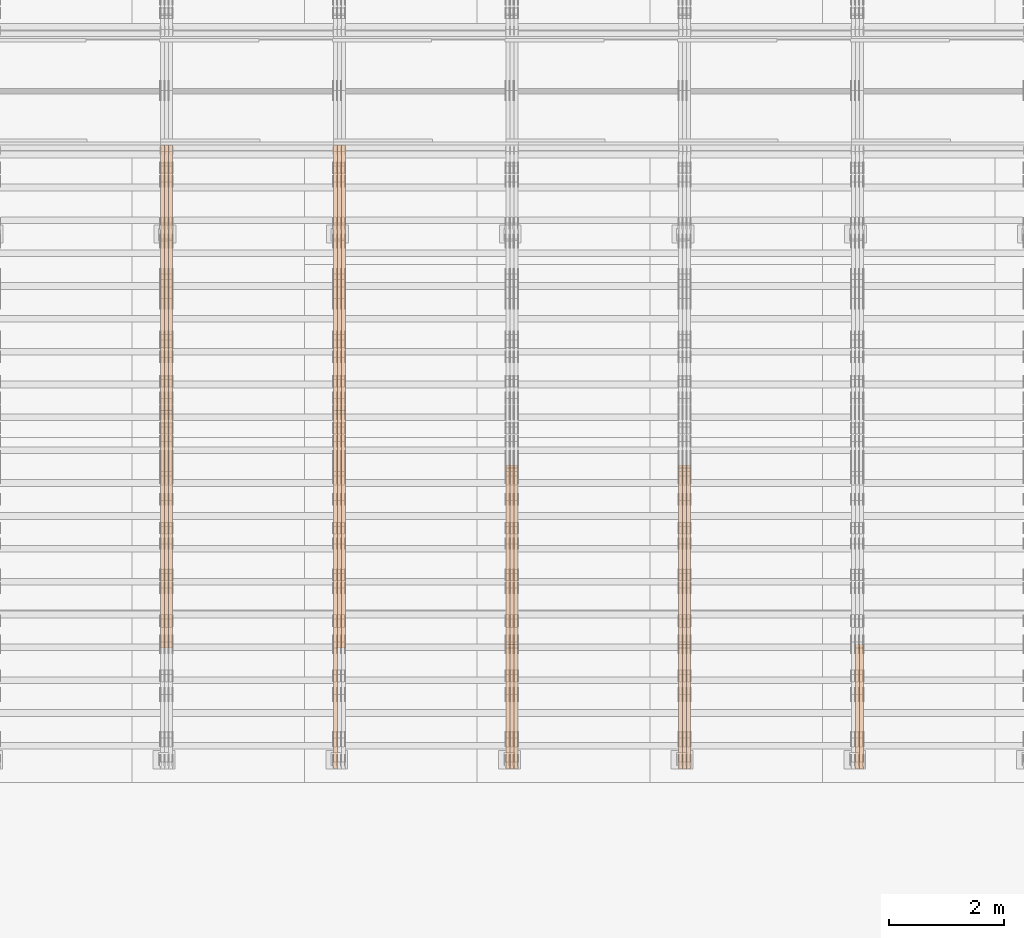
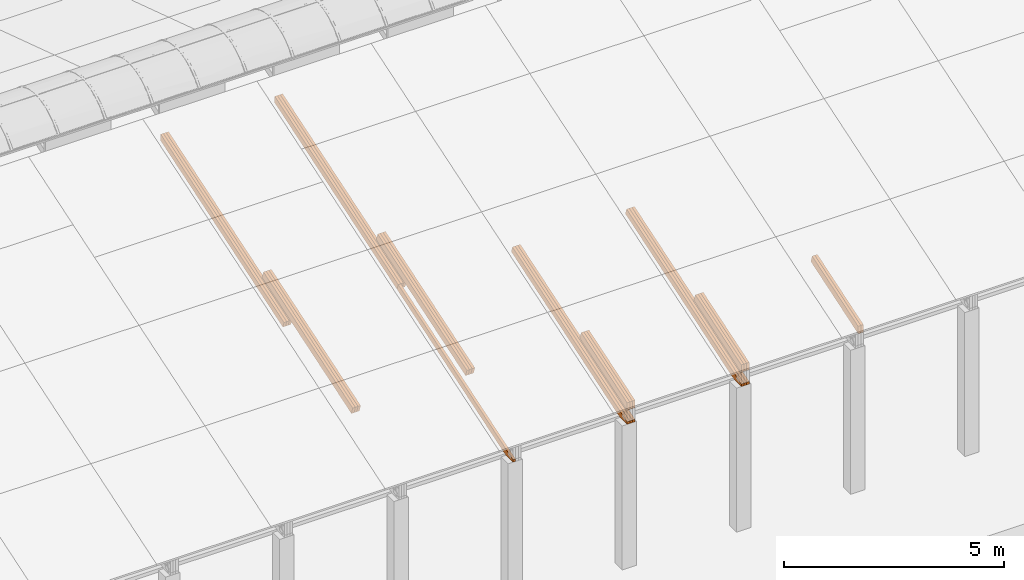
# One storey, part 16 of 385: 27 proxies.
"""IFC2X3 building model written with IfcOpenShell, lengths in millimetres."""

from ifc_helpers import new_model, entity, si_unit, converted_unit, derived_unit, direction, frame, origin, place, context, subcontext, project, spatial, polyline, outline, extrude, source, transform, mapped, material, type_object, type_shapes, element, save


model = new_model("IFC2X3")

# Units and contexts
model_context = context("Model", 3, precision=0.01, world=origin(), true_north=direction((6.12303176911189e-17, 1.0)))
body_context = subcontext(model_context, "Body", "Model", "MODEL_VIEW")
ifc_project = project(units=[si_unit("LENGTHUNIT", "METRE", prefix="MILLI"), si_unit("AREAUNIT", "SQUARE_METRE"), si_unit("VOLUMEUNIT", "CUBIC_METRE"), converted_unit("PLANEANGLEUNIT", "DEGREE", entity("IfcRatioMeasure", 0.0174532925199433), si_unit("PLANEANGLEUNIT", "RADIAN"), dimensions=[0, 0, 0, 0, 0, 0, 0]), si_unit("MASSUNIT", "GRAM", prefix="KILO"), derived_unit("MASSDENSITYUNIT", [(si_unit("MASSUNIT", "GRAM", prefix="KILO"), 1), (si_unit("LENGTHUNIT", "METRE"), -3)]), si_unit("TIMEUNIT", "SECOND"), si_unit("FREQUENCYUNIT", "HERTZ"), si_unit("THERMODYNAMICTEMPERATUREUNIT", "DEGREE_CELSIUS"), derived_unit("THERMALTRANSMITTANCEUNIT", [(si_unit("MASSUNIT", "GRAM", prefix="KILO"), 1), (si_unit("THERMODYNAMICTEMPERATUREUNIT", "KELVIN"), -1), (si_unit("TIMEUNIT", "SECOND"), -3)]), derived_unit("VOLUMETRICFLOWRATEUNIT", [(si_unit("LENGTHUNIT", "METRE"), 3), (si_unit("TIMEUNIT", "SECOND"), -1)]), si_unit("ELECTRICCURRENTUNIT", "AMPERE"), si_unit("ELECTRICVOLTAGEUNIT", "VOLT"), si_unit("POWERUNIT", "WATT"), si_unit("FORCEUNIT", "NEWTON", prefix="KILO"), si_unit("ILLUMINANCEUNIT", "LUX"), si_unit("LUMINOUSFLUXUNIT", "LUMEN"), si_unit("LUMINOUSINTENSITYUNIT", "CANDELA"), derived_unit("USERDEFINED", [(si_unit("MASSUNIT", "GRAM", prefix="KILO"), -1), (si_unit("LENGTHUNIT", "METRE"), -2), (si_unit("TIMEUNIT", "SECOND"), 3), (si_unit("LUMINOUSFLUXUNIT", "LUMEN"), 1)]), derived_unit("LINEARVELOCITYUNIT", [(si_unit("LENGTHUNIT", "METRE"), 1), (si_unit("TIMEUNIT", "SECOND"), -1)]), si_unit("PRESSUREUNIT", "PASCAL"), derived_unit("USERDEFINED", [(si_unit("LENGTHUNIT", "METRE"), -2), (si_unit("MASSUNIT", "GRAM", prefix="KILO"), 1), (si_unit("TIMEUNIT", "SECOND"), -2)])], contexts=[model_context])

# Site, building, storey
site_placement = place(None, origin())
site = spatial("IfcSite", under=ifc_project, at=site_placement, CompositionType="ELEMENT")
building_placement = place(site_placement, origin())
building = spatial("IfcBuilding", under=site, at=building_placement, CompositionType="ELEMENT")
storey_placement = place(building_placement, origin())
storey = spatial("IfcBuildingStorey", under=building, at=storey_placement, Name="Default", CompositionType="ELEMENT", Elevation=0.0)

# Proxies
ifc_material_1 = material(Name="IfcSurfaceStyle #352167")
building_element_proxy_type_1 = type_object("IfcBuildingElementProxyType", Name="T1-T3 352165", PredefinedType="NOTDEFINED", material=ifc_material_1)
shared_shape_1 = source(origin(), body_context, "Body", "SweptSolid", [
    extrude(outline(polyline([(-1085.54462735035, -97.5001496742589), (1117.22361141796, -97.5001496742589), (1117.22498157786, 97.5001496742589), (-1148.90396564547, 97.5001496742589), (-1085.54462735035, -97.5001496742589)])), frame((1117.22498157786, 97.5001496742589, 0.0), z_axis=(0.0, 0.0, 1.0), x_axis=(-1.0, 0.0, 0.0)), (0.0, 0.0, 1.0), 69.9999999999999),
])
type_shapes(building_element_proxy_type_1, [shared_shape_1])
proxy_1_placement = place(building_placement, frame((30385.0, 5095.216796875, 1095.23693847656), z_axis=(-1.0, 0.0, 0.0), x_axis=(0.0, -0.951056516295154, -0.309016994374948)))
element("IfcBuildingElementProxy", 1, at=proxy_1_placement, inside=storey, type_object=building_element_proxy_type_1, material=ifc_material_1, Name="T1-T3", context=body_context, shape_type="MappedRepresentation", body=[
    mapped(shared_shape_1, transform((0.0, 0.0, 0.0), scale=1.0)),
])
ifc_material_2 = material(Name="IfcSurfaceStyle #352110")
building_element_proxy_type_2 = type_object("IfcBuildingElementProxyType", Name="T1-T3 352108", PredefinedType="NOTDEFINED", material=ifc_material_2)
shared_shape_2 = source(origin(), body_context, "Body", "SweptSolid", [
    extrude(outline(polyline([(-1085.54462735035, -97.5001496742589), (1117.22361141796, -97.5001496742589), (1117.22498157786, 97.5001496742589), (-1148.90396564547, 97.5001496742589), (-1085.54462735035, -97.5001496742589)])), frame((1117.22498157786, 97.5001496742589, 0.0), z_axis=(0.0, 0.0, 1.0), x_axis=(-1.0, 0.0, 0.0)), (0.0, 0.0, 1.0), 69.9999999999999),
])
type_shapes(building_element_proxy_type_2, [shared_shape_2])
proxy_2_placement = place(building_placement, frame((30315.0, 5095.216796875, 1095.23693847656), z_axis=(-1.0, 0.0, 0.0), x_axis=(0.0, -0.951056516295154, -0.309016994374948)))
element("IfcBuildingElementProxy", 2, at=proxy_2_placement, inside=storey, type_object=building_element_proxy_type_2, material=ifc_material_2, Name="T1-T3", context=body_context, shape_type="MappedRepresentation", body=[
    mapped(shared_shape_2, transform((0.0, 0.0, 0.0), scale=1.0)),
])
ifc_material_3 = material(Name="IfcSurfaceStyle #317735")
building_element_proxy_type_3 = type_object("IfcBuildingElementProxyType", Name="T1-T3 317733", PredefinedType="NOTDEFINED", material=ifc_material_3)
shared_shape_3 = source(origin(), body_context, "Body", "SweptSolid", [
    extrude(outline(polyline([(-1085.54462735035, -97.5001496742589), (1117.22361141796, -97.5001496742589), (1117.22498157786, 97.5001496742589), (-1148.90396564547, 97.5001496742589), (-1085.54462735035, -97.5001496742589)])), frame((1117.22498157786, 97.5001496742589, 0.0), z_axis=(0.0, 0.0, 1.0), x_axis=(-1.0, 0.0, 0.0)), (0.0, 0.0, 1.0), 69.9999999999999),
])
type_shapes(building_element_proxy_type_3, [shared_shape_3])
proxy_3_placement = place(building_placement, frame((27385.0, 5095.216796875, 1095.23693847656), z_axis=(-1.0, 0.0, 0.0), x_axis=(0.0, -0.951056516295154, -0.309016994374948)))
element("IfcBuildingElementProxy", 3, at=proxy_3_placement, inside=storey, type_object=building_element_proxy_type_3, material=ifc_material_3, Name="T1-T3", context=body_context, shape_type="MappedRepresentation", body=[
    mapped(shared_shape_3, transform((0.0, 0.0, 0.0), scale=1.0)),
])
ifc_material_4 = material(Name="IfcSurfaceStyle #317678")
building_element_proxy_type_4 = type_object("IfcBuildingElementProxyType", Name="T1-T3 317676", PredefinedType="NOTDEFINED", material=ifc_material_4)
shared_shape_4 = source(origin(), body_context, "Body", "SweptSolid", [
    extrude(outline(polyline([(-1085.54462735035, -97.5001496742589), (1117.22361141796, -97.5001496742589), (1117.22498157786, 97.5001496742589), (-1148.90396564547, 97.5001496742589), (-1085.54462735035, -97.5001496742589)])), frame((1117.22498157786, 97.5001496742589, 0.0), z_axis=(0.0, 0.0, 1.0), x_axis=(-1.0, 0.0, 0.0)), (0.0, 0.0, 1.0), 69.9999999999999),
])
type_shapes(building_element_proxy_type_4, [shared_shape_4])
proxy_4_placement = place(building_placement, frame((27315.0, 5095.216796875, 1095.23693847656), z_axis=(-1.0, 0.0, 0.0), x_axis=(0.0, -0.951056516295154, -0.309016994374948)))
element("IfcBuildingElementProxy", 4, at=proxy_4_placement, inside=storey, type_object=building_element_proxy_type_4, material=ifc_material_4, Name="T1-T3", context=body_context, shape_type="MappedRepresentation", body=[
    mapped(shared_shape_4, transform((0.0, 0.0, 0.0), scale=1.0)),
])
ifc_material_5 = material(Name="IfcSurfaceStyle #317621")
building_element_proxy_type_5 = type_object("IfcBuildingElementProxyType", Name="T1-T3 317619", PredefinedType="NOTDEFINED", material=ifc_material_5)
shared_shape_5 = source(origin(), body_context, "Body", "SweptSolid", [
    extrude(outline(polyline([(-1085.54462735035, -97.5001496742589), (1117.22361141796, -97.5001496742589), (1117.22498157786, 97.5001496742589), (-1148.90396564547, 97.5001496742589), (-1085.54462735035, -97.5001496742589)])), frame((1117.22498157786, 97.5001496742589, 0.0), z_axis=(0.0, 0.0, 1.0), x_axis=(-1.0, 0.0, 0.0)), (0.0, 0.0, 1.0), 69.9999999999999),
])
type_shapes(building_element_proxy_type_5, [shared_shape_5])
proxy_5_placement = place(building_placement, frame((27245.0, 5095.216796875, 1095.23693847656), z_axis=(-1.0, 0.0, 0.0), x_axis=(0.0, -0.951056516295154, -0.309016994374948)))
element("IfcBuildingElementProxy", 5, at=proxy_5_placement, inside=storey, type_object=building_element_proxy_type_5, material=ifc_material_5, Name="T1-T3", context=body_context, shape_type="MappedRepresentation", body=[
    mapped(shared_shape_5, transform((0.0, 0.0, 0.0), scale=1.0)),
])
ifc_material_6 = material(Name="IfcSurfaceStyle #317051")
building_element_proxy_type_6 = type_object("IfcBuildingElementProxyType", Name="T1-B5 317049", PredefinedType="NOTDEFINED", material=ifc_material_6)
shared_shape_6 = source(origin(), body_context, "Body", "SweptSolid", [
    extrude(outline(polyline([(-3238.20553797979, -89.0131148793731), (1950.26357999126, -89.0131148793731), (2273.6227955316, 16.0525968934038), (2252.52438864378, 80.9868164326712), (-3238.20522618685, 80.9868164326712), (-3238.20553797979, -89.0131148793731)])), frame((2273.6227955316, 80.9869419088758, 0.0), z_axis=(0.0, 0.0, 1.0), x_axis=(-1.0, 0.0, 0.0)), (0.0, 0.0, 1.0), 69.9999999999997),
])
type_shapes(building_element_proxy_type_6, [shared_shape_6])
proxy_6_placement = place(building_placement, frame((27385.0, 2919.93418387161, 61.7562319586341), z_axis=(-1.0, 0.0, 0.0), x_axis=(0.0, 0.951056516295124, 0.309016994375039)))
element("IfcBuildingElementProxy", 6, at=proxy_6_placement, inside=storey, type_object=building_element_proxy_type_6, material=ifc_material_6, Name="T1-B5", context=body_context, shape_type="MappedRepresentation", body=[
    mapped(shared_shape_6, transform((0.0, 0.0, 0.0), scale=1.0)),
])
ifc_material_7 = material(Name="IfcSurfaceStyle #316985")
building_element_proxy_type_7 = type_object("IfcBuildingElementProxyType", Name="T1-B5 316983", PredefinedType="NOTDEFINED", material=ifc_material_7)
shared_shape_7 = source(origin(), body_context, "Body", "SweptSolid", [
    extrude(outline(polyline([(-3238.20553797979, -89.0131148793731), (1950.26357999126, -89.0131148793731), (2273.6227955316, 16.0525968934038), (2252.52438864378, 80.9868164326712), (-3238.20522618685, 80.9868164326712), (-3238.20553797979, -89.0131148793731)])), frame((2273.6227955316, 80.9869419088758, 0.0), z_axis=(0.0, 0.0, 1.0), x_axis=(-1.0, 0.0, 0.0)), (0.0, 0.0, 1.0), 69.9999999999997),
])
type_shapes(building_element_proxy_type_7, [shared_shape_7])
proxy_7_placement = place(building_placement, frame((27315.0, 2919.93418387161, 61.7562319586341), z_axis=(-1.0, 0.0, 0.0), x_axis=(0.0, 0.951056516295124, 0.309016994375039)))
element("IfcBuildingElementProxy", 7, at=proxy_7_placement, inside=storey, type_object=building_element_proxy_type_7, material=ifc_material_7, Name="T1-B5", context=body_context, shape_type="MappedRepresentation", body=[
    mapped(shared_shape_7, transform((0.0, 0.0, 0.0), scale=1.0)),
])
ifc_material_8 = material(Name="IfcSurfaceStyle #316919")
building_element_proxy_type_8 = type_object("IfcBuildingElementProxyType", Name="T1-B5 316917", PredefinedType="NOTDEFINED", material=ifc_material_8)
shared_shape_8 = source(origin(), body_context, "Body", "SweptSolid", [
    extrude(outline(polyline([(-3238.20553797979, -89.0131148793731), (1950.26357999126, -89.0131148793731), (2273.6227955316, 16.0525968934038), (2252.52438864378, 80.9868164326712), (-3238.20522618685, 80.9868164326712), (-3238.20553797979, -89.0131148793731)])), frame((2273.6227955316, 80.9869419088758, 0.0), z_axis=(0.0, 0.0, 1.0), x_axis=(-1.0, 0.0, 0.0)), (0.0, 0.0, 1.0), 69.9999999999997),
])
type_shapes(building_element_proxy_type_8, [shared_shape_8])
proxy_8_placement = place(building_placement, frame((27245.0, 2919.93418387161, 61.7562319586341), z_axis=(-1.0, 0.0, 0.0), x_axis=(0.0, 0.951056516295124, 0.309016994375039)))
element("IfcBuildingElementProxy", 8, at=proxy_8_placement, inside=storey, type_object=building_element_proxy_type_8, material=ifc_material_8, Name="T1-B5", context=body_context, shape_type="MappedRepresentation", body=[
    mapped(shared_shape_8, transform((0.0, 0.0, 0.0), scale=1.0)),
])
ifc_material_9 = material(Name="IfcSurfaceStyle #283303")
building_element_proxy_type_9 = type_object("IfcBuildingElementProxyType", Name="T1-T3 283301", PredefinedType="NOTDEFINED", material=ifc_material_9)
shared_shape_9 = source(origin(), body_context, "Body", "SweptSolid", [
    extrude(outline(polyline([(-1085.54462735035, -97.5001496742589), (1117.22361141796, -97.5001496742589), (1117.22498157786, 97.5001496742589), (-1148.90396564547, 97.5001496742589), (-1085.54462735035, -97.5001496742589)])), frame((1117.22498157786, 97.5001496742589, 0.0), z_axis=(0.0, 0.0, 1.0), x_axis=(-1.0, 0.0, 0.0)), (0.0, 0.0, 1.0), 69.9999999999999),
])
type_shapes(building_element_proxy_type_9, [shared_shape_9])
proxy_9_placement = place(building_placement, frame((24385.0, 5095.216796875, 1095.23693847656), z_axis=(-1.0, 0.0, 0.0), x_axis=(0.0, -0.951056516295154, -0.309016994374948)))
element("IfcBuildingElementProxy", 9, at=proxy_9_placement, inside=storey, type_object=building_element_proxy_type_9, material=ifc_material_9, Name="T1-T3", context=body_context, shape_type="MappedRepresentation", body=[
    mapped(shared_shape_9, transform((0.0, 0.0, 0.0), scale=1.0)),
])
ifc_material_10 = material(Name="IfcSurfaceStyle #283246")
building_element_proxy_type_10 = type_object("IfcBuildingElementProxyType", Name="T1-T3 283244", PredefinedType="NOTDEFINED", material=ifc_material_10)
shared_shape_10 = source(origin(), body_context, "Body", "SweptSolid", [
    extrude(outline(polyline([(-1085.54462735035, -97.5001496742589), (1117.22361141796, -97.5001496742589), (1117.22498157786, 97.5001496742589), (-1148.90396564547, 97.5001496742589), (-1085.54462735035, -97.5001496742589)])), frame((1117.22498157786, 97.5001496742589, 0.0), z_axis=(0.0, 0.0, 1.0), x_axis=(-1.0, 0.0, 0.0)), (0.0, 0.0, 1.0), 69.9999999999999),
])
type_shapes(building_element_proxy_type_10, [shared_shape_10])
proxy_10_placement = place(building_placement, frame((24315.0, 5095.216796875, 1095.23693847656), z_axis=(-1.0, 0.0, 0.0), x_axis=(0.0, -0.951056516295154, -0.309016994374948)))
element("IfcBuildingElementProxy", 10, at=proxy_10_placement, inside=storey, type_object=building_element_proxy_type_10, material=ifc_material_10, Name="T1-T3", context=body_context, shape_type="MappedRepresentation", body=[
    mapped(shared_shape_10, transform((0.0, 0.0, 0.0), scale=1.0)),
])
ifc_material_11 = material(Name="IfcSurfaceStyle #283189")
building_element_proxy_type_11 = type_object("IfcBuildingElementProxyType", Name="T1-T3 283187", PredefinedType="NOTDEFINED", material=ifc_material_11)
shared_shape_11 = source(origin(), body_context, "Body", "SweptSolid", [
    extrude(outline(polyline([(-1085.54462735035, -97.5001496742589), (1117.22361141796, -97.5001496742589), (1117.22498157786, 97.5001496742589), (-1148.90396564547, 97.5001496742589), (-1085.54462735035, -97.5001496742589)])), frame((1117.22498157786, 97.5001496742589, 0.0), z_axis=(0.0, 0.0, 1.0), x_axis=(-1.0, 0.0, 0.0)), (0.0, 0.0, 1.0), 69.9999999999999),
])
type_shapes(building_element_proxy_type_11, [shared_shape_11])
proxy_11_placement = place(building_placement, frame((24245.0, 5095.216796875, 1095.23693847656), z_axis=(-1.0, 0.0, 0.0), x_axis=(0.0, -0.951056516295154, -0.309016994374948)))
element("IfcBuildingElementProxy", 11, at=proxy_11_placement, inside=storey, type_object=building_element_proxy_type_11, material=ifc_material_11, Name="T1-T3", context=body_context, shape_type="MappedRepresentation", body=[
    mapped(shared_shape_11, transform((0.0, 0.0, 0.0), scale=1.0)),
])
ifc_material_12 = material(Name="IfcSurfaceStyle #282619")
building_element_proxy_type_12 = type_object("IfcBuildingElementProxyType", Name="T1-B5 282617", PredefinedType="NOTDEFINED", material=ifc_material_12)
shared_shape_12 = source(origin(), body_context, "Body", "SweptSolid", [
    extrude(outline(polyline([(-3238.20553797979, -89.0131148793731), (1950.26357999126, -89.0131148793731), (2273.6227955316, 16.0525968934038), (2252.52438864378, 80.9868164326712), (-3238.20522618685, 80.9868164326712), (-3238.20553797979, -89.0131148793731)])), frame((2273.6227955316, 80.9869419088758, 0.0), z_axis=(0.0, 0.0, 1.0), x_axis=(-1.0, 0.0, 0.0)), (0.0, 0.0, 1.0), 69.9999999999997),
])
type_shapes(building_element_proxy_type_12, [shared_shape_12])
proxy_12_placement = place(building_placement, frame((24385.0, 2919.93418387161, 61.7562319586341), z_axis=(-1.0, 0.0, 0.0), x_axis=(0.0, 0.951056516295124, 0.309016994375039)))
element("IfcBuildingElementProxy", 12, at=proxy_12_placement, inside=storey, type_object=building_element_proxy_type_12, material=ifc_material_12, Name="T1-B5", context=body_context, shape_type="MappedRepresentation", body=[
    mapped(shared_shape_12, transform((0.0, 0.0, 0.0), scale=1.0)),
])
ifc_material_13 = material(Name="IfcSurfaceStyle #282553")
building_element_proxy_type_13 = type_object("IfcBuildingElementProxyType", Name="T1-B5 282551", PredefinedType="NOTDEFINED", material=ifc_material_13)
shared_shape_13 = source(origin(), body_context, "Body", "SweptSolid", [
    extrude(outline(polyline([(-3238.20553797979, -89.0131148793731), (1950.26357999126, -89.0131148793731), (2273.6227955316, 16.0525968934038), (2252.52438864378, 80.9868164326712), (-3238.20522618685, 80.9868164326712), (-3238.20553797979, -89.0131148793731)])), frame((2273.6227955316, 80.9869419088758, 0.0), z_axis=(0.0, 0.0, 1.0), x_axis=(-1.0, 0.0, 0.0)), (0.0, 0.0, 1.0), 69.9999999999997),
])
type_shapes(building_element_proxy_type_13, [shared_shape_13])
proxy_13_placement = place(building_placement, frame((24315.0, 2919.93418387161, 61.7562319586341), z_axis=(-1.0, 0.0, 0.0), x_axis=(0.0, 0.951056516295124, 0.309016994375039)))
element("IfcBuildingElementProxy", 13, at=proxy_13_placement, inside=storey, type_object=building_element_proxy_type_13, material=ifc_material_13, Name="T1-B5", context=body_context, shape_type="MappedRepresentation", body=[
    mapped(shared_shape_13, transform((0.0, 0.0, 0.0), scale=1.0)),
])
ifc_material_14 = material(Name="IfcSurfaceStyle #282487")
building_element_proxy_type_14 = type_object("IfcBuildingElementProxyType", Name="T1-B5 282485", PredefinedType="NOTDEFINED", material=ifc_material_14)
shared_shape_14 = source(origin(), body_context, "Body", "SweptSolid", [
    extrude(outline(polyline([(-3238.20553797979, -89.0131148793731), (1950.26357999126, -89.0131148793731), (2273.6227955316, 16.0525968934038), (2252.52438864378, 80.9868164326712), (-3238.20522618685, 80.9868164326712), (-3238.20553797979, -89.0131148793731)])), frame((2273.6227955316, 80.9869419088758, 0.0), z_axis=(0.0, 0.0, 1.0), x_axis=(-1.0, 0.0, 0.0)), (0.0, 0.0, 1.0), 69.9999999999997),
])
type_shapes(building_element_proxy_type_14, [shared_shape_14])
proxy_14_placement = place(building_placement, frame((24245.0, 2919.93418387161, 61.7562319586341), z_axis=(-1.0, 0.0, 0.0), x_axis=(0.0, 0.951056516295124, 0.309016994375039)))
element("IfcBuildingElementProxy", 14, at=proxy_14_placement, inside=storey, type_object=building_element_proxy_type_14, material=ifc_material_14, Name="T1-B5", context=body_context, shape_type="MappedRepresentation", body=[
    mapped(shared_shape_14, transform((0.0, 0.0, 0.0), scale=1.0)),
])
ifc_material_15 = material(Name="IfcSurfaceStyle #248700")
building_element_proxy_type_15 = type_object("IfcBuildingElementProxyType", Name="T1-T2 248698", PredefinedType="NOTDEFINED", material=ifc_material_15)
shared_shape_15 = source(origin(), body_context, "Body", "SweptSolid", [
    extrude(outline(polyline([(-2137.04475371072, -97.5001541485635), (2137.04431231695, -97.5001541485635), (2137.0438249446, 97.5001541485636), (-2137.04338355082, 97.5001541485635), (-2137.04475371072, -97.5001541485635)])), frame((2137.04431231695, 97.5003268035489, 0.0), z_axis=(0.0, 0.0, 1.0), x_axis=(-1.0, 0.0, 0.0)), (0.0, 0.0, 1.0), 69.9999999999997),
])
type_shapes(building_element_proxy_type_15, [shared_shape_15])
proxy_15_placement = place(building_placement, frame((21385.0, 9160.11575124697, 2416.00267194857), z_axis=(-1.0, 0.0, 0.0), x_axis=(0.0, -0.951056516295154, -0.309016994374948)))
element("IfcBuildingElementProxy", 15, at=proxy_15_placement, inside=storey, type_object=building_element_proxy_type_15, material=ifc_material_15, Name="T1-T2", context=body_context, shape_type="MappedRepresentation", body=[
    mapped(shared_shape_15, transform((0.0, 0.0, 0.0), scale=1.0)),
])
ifc_material_16 = material(Name="IfcSurfaceStyle #248643")
building_element_proxy_type_16 = type_object("IfcBuildingElementProxyType", Name="T1-T2 248641", PredefinedType="NOTDEFINED", material=ifc_material_16)
shared_shape_16 = source(origin(), body_context, "Body", "SweptSolid", [
    extrude(outline(polyline([(-2137.04475371072, -97.5001541485635), (2137.04431231695, -97.5001541485635), (2137.0438249446, 97.5001541485636), (-2137.04338355082, 97.5001541485635), (-2137.04475371072, -97.5001541485635)])), frame((2137.04431231695, 97.5003268035489, 0.0), z_axis=(0.0, 0.0, 1.0), x_axis=(-1.0, 0.0, 0.0)), (0.0, 0.0, 1.0), 69.9999999999997),
])
type_shapes(building_element_proxy_type_16, [shared_shape_16])
proxy_16_placement = place(building_placement, frame((21315.0, 9160.11575124697, 2416.00267194857), z_axis=(-1.0, 0.0, 0.0), x_axis=(0.0, -0.951056516295154, -0.309016994374948)))
element("IfcBuildingElementProxy", 16, at=proxy_16_placement, inside=storey, type_object=building_element_proxy_type_16, material=ifc_material_16, Name="T1-T2", context=body_context, shape_type="MappedRepresentation", body=[
    mapped(shared_shape_16, transform((0.0, 0.0, 0.0), scale=1.0)),
])
ifc_material_17 = material(Name="IfcSurfaceStyle #248586")
building_element_proxy_type_17 = type_object("IfcBuildingElementProxyType", Name="T1-T2 248584", PredefinedType="NOTDEFINED", material=ifc_material_17)
shared_shape_17 = source(origin(), body_context, "Body", "SweptSolid", [
    extrude(outline(polyline([(-2137.04475371072, -97.5001541485635), (2137.04431231695, -97.5001541485635), (2137.0438249446, 97.5001541485636), (-2137.04338355082, 97.5001541485635), (-2137.04475371072, -97.5001541485635)])), frame((2137.04431231695, 97.5003268035489, 0.0), z_axis=(0.0, 0.0, 1.0), x_axis=(-1.0, 0.0, 0.0)), (0.0, 0.0, 1.0), 69.9999999999997),
])
type_shapes(building_element_proxy_type_17, [shared_shape_17])
proxy_17_placement = place(building_placement, frame((21245.0, 9160.11575124697, 2416.00267194857), z_axis=(-1.0, 0.0, 0.0), x_axis=(0.0, -0.951056516295154, -0.309016994374948)))
element("IfcBuildingElementProxy", 17, at=proxy_17_placement, inside=storey, type_object=building_element_proxy_type_17, material=ifc_material_17, Name="T1-T2", context=body_context, shape_type="MappedRepresentation", body=[
    mapped(shared_shape_17, transform((0.0, 0.0, 0.0), scale=1.0)),
])
ifc_material_18 = material(Name="IfcSurfaceStyle #248358")
building_element_proxy_type_18 = type_object("IfcBuildingElementProxyType", Name="T1-B4 248356", PredefinedType="NOTDEFINED", material=ifc_material_18)
shared_shape_18 = source(origin(), body_context, "Body", "SweptSolid", [
    extrude(outline(polyline([(-2912.13310129284, -85.0000958683222), (2939.75111293783, -85.0000958683222), (2939.75142473078, 85.0000958683222), (-2967.36943637577, 85.0000958683222), (-2912.13310129284, -85.0000958683222)])), frame((2939.75142473078, 85.0000958683222, 0.0), z_axis=(0.0, 0.0, 1.0), x_axis=(-1.0, 0.0, 0.0)), (0.0, 0.0, 1.0), 69.9999999999996),
])
type_shapes(building_element_proxy_type_18, [shared_shape_18])
proxy_18_placement = place(building_placement, frame((21385.0, 8161.994140625, 1765.00476074219), z_axis=(-1.0, 0.0, 0.0), x_axis=(0.0, 0.951056516295124, 0.309016994375039)))
element("IfcBuildingElementProxy", 18, at=proxy_18_placement, inside=storey, type_object=building_element_proxy_type_18, material=ifc_material_18, Name="T1-B4", context=body_context, shape_type="MappedRepresentation", body=[
    mapped(shared_shape_18, transform((0.0, 0.0, 0.0), scale=1.0)),
])
ifc_material_19 = material(Name="IfcSurfaceStyle #248301")
building_element_proxy_type_19 = type_object("IfcBuildingElementProxyType", Name="T1-B4 248299", PredefinedType="NOTDEFINED", material=ifc_material_19)
shared_shape_19 = source(origin(), body_context, "Body", "SweptSolid", [
    extrude(outline(polyline([(-2912.13310129284, -85.0000958683222), (2939.75111293783, -85.0000958683222), (2939.75142473078, 85.0000958683222), (-2967.36943637577, 85.0000958683222), (-2912.13310129284, -85.0000958683222)])), frame((2939.75142473078, 85.0000958683222, 0.0), z_axis=(0.0, 0.0, 1.0), x_axis=(-1.0, 0.0, 0.0)), (0.0, 0.0, 1.0), 69.9999999999996),
])
type_shapes(building_element_proxy_type_19, [shared_shape_19])
proxy_19_placement = place(building_placement, frame((21315.0, 8161.994140625, 1765.00476074219), z_axis=(-1.0, 0.0, 0.0), x_axis=(0.0, 0.951056516295124, 0.309016994375039)))
element("IfcBuildingElementProxy", 19, at=proxy_19_placement, inside=storey, type_object=building_element_proxy_type_19, material=ifc_material_19, Name="T1-B4", context=body_context, shape_type="MappedRepresentation", body=[
    mapped(shared_shape_19, transform((0.0, 0.0, 0.0), scale=1.0)),
])
ifc_material_20 = material(Name="IfcSurfaceStyle #248244")
building_element_proxy_type_20 = type_object("IfcBuildingElementProxyType", Name="T1-B4 248242", PredefinedType="NOTDEFINED", material=ifc_material_20)
shared_shape_20 = source(origin(), body_context, "Body", "SweptSolid", [
    extrude(outline(polyline([(-2912.13310129284, -85.0000958683222), (2939.75111293783, -85.0000958683222), (2939.75142473078, 85.0000958683222), (-2967.36943637577, 85.0000958683222), (-2912.13310129284, -85.0000958683222)])), frame((2939.75142473078, 85.0000958683222, 0.0), z_axis=(0.0, 0.0, 1.0), x_axis=(-1.0, 0.0, 0.0)), (0.0, 0.0, 1.0), 69.9999999999996),
])
type_shapes(building_element_proxy_type_20, [shared_shape_20])
proxy_20_placement = place(building_placement, frame((21245.0, 8161.994140625, 1765.00476074219), z_axis=(-1.0, 0.0, 0.0), x_axis=(0.0, 0.951056516295124, 0.309016994375039)))
element("IfcBuildingElementProxy", 20, at=proxy_20_placement, inside=storey, type_object=building_element_proxy_type_20, material=ifc_material_20, Name="T1-B4", context=body_context, shape_type="MappedRepresentation", body=[
    mapped(shared_shape_20, transform((0.0, 0.0, 0.0), scale=1.0)),
])
ifc_material_21 = material(Name="IfcSurfaceStyle #248055")
building_element_proxy_type_21 = type_object("IfcBuildingElementProxyType", Name="T1-B5 248053", PredefinedType="NOTDEFINED", material=ifc_material_21)
shared_shape_21 = source(origin(), body_context, "Body", "SweptSolid", [
    extrude(outline(polyline([(-3238.20553797979, -89.0131148793731), (1950.26357999126, -89.0131148793731), (2273.6227955316, 16.0525968934038), (2252.52438864378, 80.9868164326712), (-3238.20522618685, 80.9868164326712), (-3238.20553797979, -89.0131148793731)])), frame((2273.6227955316, 80.9869419088758, 0.0), z_axis=(0.0, 0.0, 1.0), x_axis=(-1.0, 0.0, 0.0)), (0.0, 0.0, 1.0), 69.9999999999997),
])
type_shapes(building_element_proxy_type_21, [shared_shape_21])
proxy_21_placement = place(building_placement, frame((21245.0, 2919.93418387161, 61.7562319586341), z_axis=(-1.0, 0.0, 0.0), x_axis=(0.0, 0.951056516295124, 0.309016994375039)))
element("IfcBuildingElementProxy", 21, at=proxy_21_placement, inside=storey, type_object=building_element_proxy_type_21, material=ifc_material_21, Name="T1-B5", context=body_context, shape_type="MappedRepresentation", body=[
    mapped(shared_shape_21, transform((0.0, 0.0, 0.0), scale=1.0)),
])
ifc_material_22 = material(Name="IfcSurfaceStyle #214268")
building_element_proxy_type_22 = type_object("IfcBuildingElementProxyType", Name="T1-T2 214266", PredefinedType="NOTDEFINED", material=ifc_material_22)
shared_shape_22 = source(origin(), body_context, "Body", "SweptSolid", [
    extrude(outline(polyline([(-2137.04475371072, -97.5001541485635), (2137.04431231695, -97.5001541485635), (2137.0438249446, 97.5001541485636), (-2137.04338355082, 97.5001541485635), (-2137.04475371072, -97.5001541485635)])), frame((2137.04431231695, 97.5003268035489, 0.0), z_axis=(0.0, 0.0, 1.0), x_axis=(-1.0, 0.0, 0.0)), (0.0, 0.0, 1.0), 69.9999999999997),
])
type_shapes(building_element_proxy_type_22, [shared_shape_22])
proxy_22_placement = place(building_placement, frame((18385.0, 9160.11575124697, 2416.00267194857), z_axis=(-1.0, 0.0, 0.0), x_axis=(0.0, -0.951056516295154, -0.309016994374948)))
element("IfcBuildingElementProxy", 22, at=proxy_22_placement, inside=storey, type_object=building_element_proxy_type_22, material=ifc_material_22, Name="T1-T2", context=body_context, shape_type="MappedRepresentation", body=[
    mapped(shared_shape_22, transform((0.0, 0.0, 0.0), scale=1.0)),
])
ifc_material_23 = material(Name="IfcSurfaceStyle #214211")
building_element_proxy_type_23 = type_object("IfcBuildingElementProxyType", Name="T1-T2 214209", PredefinedType="NOTDEFINED", material=ifc_material_23)
shared_shape_23 = source(origin(), body_context, "Body", "SweptSolid", [
    extrude(outline(polyline([(-2137.04475371072, -97.5001541485635), (2137.04431231695, -97.5001541485635), (2137.0438249446, 97.5001541485636), (-2137.04338355082, 97.5001541485635), (-2137.04475371072, -97.5001541485635)])), frame((2137.04431231695, 97.5003268035489, 0.0), z_axis=(0.0, 0.0, 1.0), x_axis=(-1.0, 0.0, 0.0)), (0.0, 0.0, 1.0), 69.9999999999997),
])
type_shapes(building_element_proxy_type_23, [shared_shape_23])
proxy_23_placement = place(building_placement, frame((18315.0, 9160.11575124697, 2416.00267194857), z_axis=(-1.0, 0.0, 0.0), x_axis=(0.0, -0.951056516295154, -0.309016994374948)))
element("IfcBuildingElementProxy", 23, at=proxy_23_placement, inside=storey, type_object=building_element_proxy_type_23, material=ifc_material_23, Name="T1-T2", context=body_context, shape_type="MappedRepresentation", body=[
    mapped(shared_shape_23, transform((0.0, 0.0, 0.0), scale=1.0)),
])
ifc_material_24 = material(Name="IfcSurfaceStyle #214154")
building_element_proxy_type_24 = type_object("IfcBuildingElementProxyType", Name="T1-T2 214152", PredefinedType="NOTDEFINED", material=ifc_material_24)
shared_shape_24 = source(origin(), body_context, "Body", "SweptSolid", [
    extrude(outline(polyline([(-2137.04475371072, -97.5001541485635), (2137.04431231695, -97.5001541485635), (2137.0438249446, 97.5001541485636), (-2137.04338355082, 97.5001541485635), (-2137.04475371072, -97.5001541485635)])), frame((2137.04431231695, 97.5003268035489, 0.0), z_axis=(0.0, 0.0, 1.0), x_axis=(-1.0, 0.0, 0.0)), (0.0, 0.0, 1.0), 69.9999999999997),
])
type_shapes(building_element_proxy_type_24, [shared_shape_24])
proxy_24_placement = place(building_placement, frame((18245.0, 9160.11575124697, 2416.00267194857), z_axis=(-1.0, 0.0, 0.0), x_axis=(0.0, -0.951056516295154, -0.309016994374948)))
element("IfcBuildingElementProxy", 24, at=proxy_24_placement, inside=storey, type_object=building_element_proxy_type_24, material=ifc_material_24, Name="T1-T2", context=body_context, shape_type="MappedRepresentation", body=[
    mapped(shared_shape_24, transform((0.0, 0.0, 0.0), scale=1.0)),
])
ifc_material_25 = material(Name="IfcSurfaceStyle #213926")
building_element_proxy_type_25 = type_object("IfcBuildingElementProxyType", Name="T1-B4 213924", PredefinedType="NOTDEFINED", material=ifc_material_25)
shared_shape_25 = source(origin(), body_context, "Body", "SweptSolid", [
    extrude(outline(polyline([(-2912.13310129284, -85.0000958683222), (2939.75111293783, -85.0000958683222), (2939.75142473078, 85.0000958683222), (-2967.36943637577, 85.0000958683222), (-2912.13310129284, -85.0000958683222)])), frame((2939.75142473078, 85.0000958683222, 0.0), z_axis=(0.0, 0.0, 1.0), x_axis=(-1.0, 0.0, 0.0)), (0.0, 0.0, 1.0), 69.9999999999996),
])
type_shapes(building_element_proxy_type_25, [shared_shape_25])
proxy_25_placement = place(building_placement, frame((18385.0, 8161.994140625, 1765.00476074219), z_axis=(-1.0, 0.0, 0.0), x_axis=(0.0, 0.951056516295124, 0.309016994375039)))
element("IfcBuildingElementProxy", 25, at=proxy_25_placement, inside=storey, type_object=building_element_proxy_type_25, material=ifc_material_25, Name="T1-B4", context=body_context, shape_type="MappedRepresentation", body=[
    mapped(shared_shape_25, transform((0.0, 0.0, 0.0), scale=1.0)),
])
ifc_material_26 = material(Name="IfcSurfaceStyle #213869")
building_element_proxy_type_26 = type_object("IfcBuildingElementProxyType", Name="T1-B4 213867", PredefinedType="NOTDEFINED", material=ifc_material_26)
shared_shape_26 = source(origin(), body_context, "Body", "SweptSolid", [
    extrude(outline(polyline([(-2912.13310129284, -85.0000958683222), (2939.75111293783, -85.0000958683222), (2939.75142473078, 85.0000958683222), (-2967.36943637577, 85.0000958683222), (-2912.13310129284, -85.0000958683222)])), frame((2939.75142473078, 85.0000958683222, 0.0), z_axis=(0.0, 0.0, 1.0), x_axis=(-1.0, 0.0, 0.0)), (0.0, 0.0, 1.0), 69.9999999999996),
])
type_shapes(building_element_proxy_type_26, [shared_shape_26])
proxy_26_placement = place(building_placement, frame((18315.0, 8161.994140625, 1765.00476074219), z_axis=(-1.0, 0.0, 0.0), x_axis=(0.0, 0.951056516295124, 0.309016994375039)))
element("IfcBuildingElementProxy", 26, at=proxy_26_placement, inside=storey, type_object=building_element_proxy_type_26, material=ifc_material_26, Name="T1-B4", context=body_context, shape_type="MappedRepresentation", body=[
    mapped(shared_shape_26, transform((0.0, 0.0, 0.0), scale=1.0)),
])
ifc_material_27 = material(Name="IfcSurfaceStyle #213812")
building_element_proxy_type_27 = type_object("IfcBuildingElementProxyType", Name="T1-B4 213810", PredefinedType="NOTDEFINED", material=ifc_material_27)
shared_shape_27 = source(origin(), body_context, "Body", "SweptSolid", [
    extrude(outline(polyline([(-2912.13310129284, -85.0000958683222), (2939.75111293783, -85.0000958683222), (2939.75142473078, 85.0000958683222), (-2967.36943637577, 85.0000958683222), (-2912.13310129284, -85.0000958683222)])), frame((2939.75142473078, 85.0000958683222, 0.0), z_axis=(0.0, 0.0, 1.0), x_axis=(-1.0, 0.0, 0.0)), (0.0, 0.0, 1.0), 69.9999999999996),
])
type_shapes(building_element_proxy_type_27, [shared_shape_27])
proxy_27_placement = place(building_placement, frame((18245.0, 8161.994140625, 1765.00476074219), z_axis=(-1.0, 0.0, 0.0), x_axis=(0.0, 0.951056516295124, 0.309016994375039)))
element("IfcBuildingElementProxy", 27, at=proxy_27_placement, inside=storey, type_object=building_element_proxy_type_27, material=ifc_material_27, Name="T1-B4", context=body_context, shape_type="MappedRepresentation", body=[
    mapped(shared_shape_27, transform((0.0, 0.0, 0.0), scale=1.0)),
])

save(model, "model.ifc")
